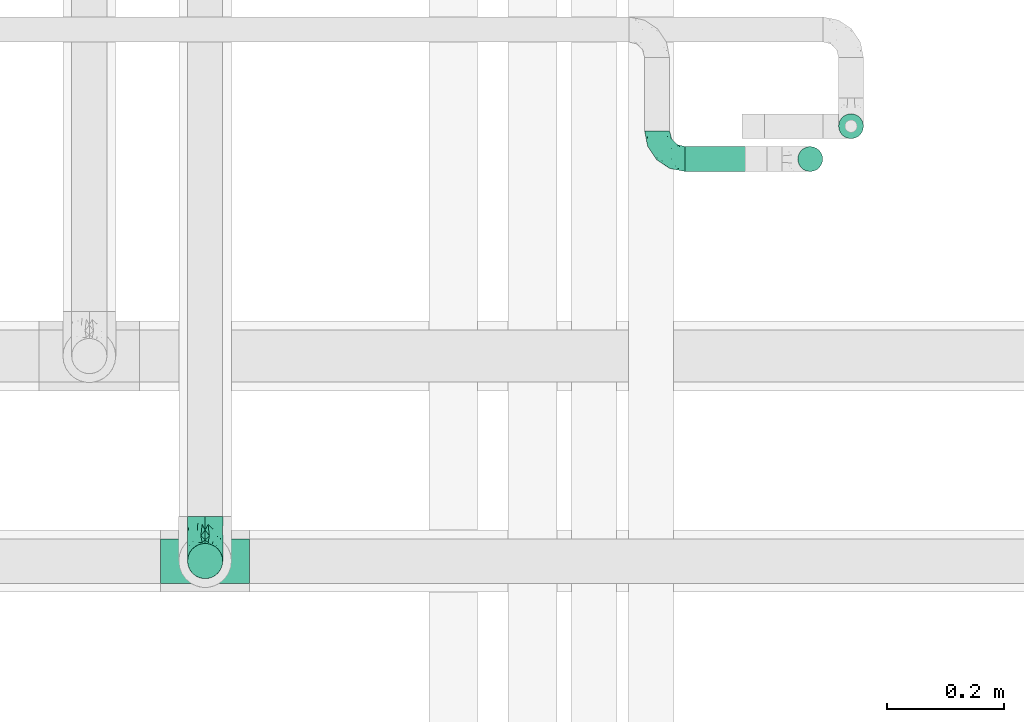
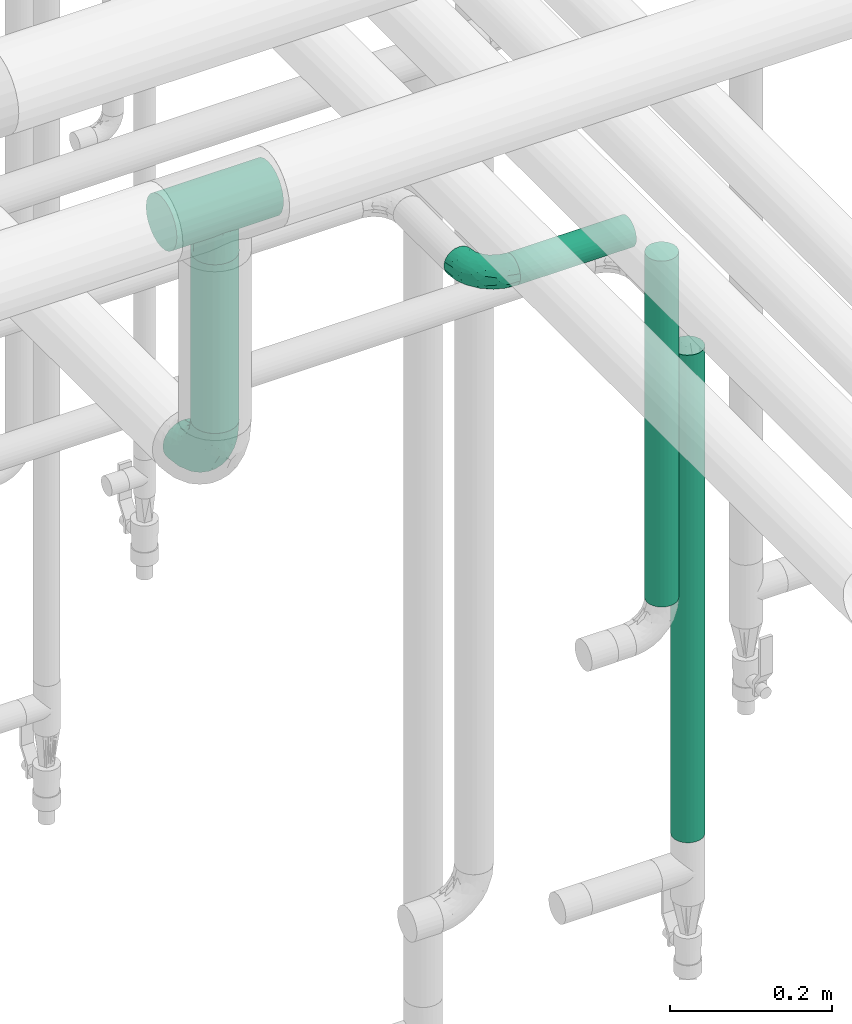
# One storey, part 574 of 824: 4 flow segments, 3 flow fittings.
"""IFC2X3 building model written with IfcOpenShell, lengths in millimetres."""

from ifc_helpers import new_model, entity, si_unit, converted_unit, derived_unit, direction, frame, origin, origin_2d_with_axis, place, context, subcontext, project, spatial, circle, extrude, faceted_brep, source, transform, mapped, material, type_object, type_shapes, element, save


model = new_model("IFC2X3")

# Units and contexts
model_context = context("Model", 3, precision=0.01, world=origin(), true_north=direction((6.12303176911189e-17, 1.0)))
body_context = subcontext(model_context, "Body", "Model", "MODEL_VIEW")
ifc_project = project(units=[si_unit("LENGTHUNIT", "METRE", prefix="MILLI"), si_unit("AREAUNIT", "SQUARE_METRE"), si_unit("VOLUMEUNIT", "CUBIC_METRE"), converted_unit("PLANEANGLEUNIT", "DEGREE", entity("IfcRatioMeasure", 0.0174532925199433), si_unit("PLANEANGLEUNIT", "RADIAN"), dimensions=[0, 0, 0, 0, 0, 0, 0]), si_unit("MASSUNIT", "GRAM", prefix="KILO"), derived_unit("MASSDENSITYUNIT", [(si_unit("MASSUNIT", "GRAM", prefix="KILO"), 1), (si_unit("LENGTHUNIT", "METRE"), -3)]), derived_unit("MOMENTOFINERTIAUNIT", [(si_unit("LENGTHUNIT", "METRE"), 4)]), si_unit("TIMEUNIT", "SECOND"), si_unit("FREQUENCYUNIT", "HERTZ"), si_unit("THERMODYNAMICTEMPERATUREUNIT", "DEGREE_CELSIUS"), derived_unit("THERMALTRANSMITTANCEUNIT", [(si_unit("MASSUNIT", "GRAM", prefix="KILO"), 1), (si_unit("THERMODYNAMICTEMPERATUREUNIT", "KELVIN"), -1), (si_unit("TIMEUNIT", "SECOND"), -3)]), derived_unit("VOLUMETRICFLOWRATEUNIT", [(si_unit("LENGTHUNIT", "METRE"), 3), (si_unit("TIMEUNIT", "SECOND"), -1)]), derived_unit("MASSFLOWRATEUNIT", [(si_unit("MASSUNIT", "GRAM", prefix="KILO"), 1), (si_unit("TIMEUNIT", "SECOND"), -1)]), derived_unit("ROTATIONALFREQUENCYUNIT", [(si_unit("TIMEUNIT", "SECOND"), -1)]), si_unit("ELECTRICCURRENTUNIT", "AMPERE"), si_unit("ELECTRICVOLTAGEUNIT", "VOLT"), si_unit("POWERUNIT", "WATT"), si_unit("FORCEUNIT", "NEWTON", prefix="KILO"), si_unit("ILLUMINANCEUNIT", "LUX"), si_unit("LUMINOUSFLUXUNIT", "LUMEN"), si_unit("LUMINOUSINTENSITYUNIT", "CANDELA"), derived_unit("USERDEFINED", [(si_unit("MASSUNIT", "GRAM", prefix="KILO"), -1), (si_unit("LENGTHUNIT", "METRE"), -2), (si_unit("TIMEUNIT", "SECOND"), 3), (si_unit("LUMINOUSFLUXUNIT", "LUMEN"), 1)]), derived_unit("LINEARVELOCITYUNIT", [(si_unit("LENGTHUNIT", "METRE"), 1), (si_unit("TIMEUNIT", "SECOND"), -1)]), si_unit("PRESSUREUNIT", "PASCAL"), derived_unit("USERDEFINED", [(si_unit("LENGTHUNIT", "METRE"), -2), (si_unit("MASSUNIT", "GRAM", prefix="KILO"), 1), (si_unit("TIMEUNIT", "SECOND"), -2)]), derived_unit("LINEARFORCEUNIT", [(si_unit("MASSUNIT", "GRAM", prefix="KILO"), 1), (si_unit("LENGTHUNIT", "METRE"), 1), (si_unit("TIMEUNIT", "SECOND"), -2), (si_unit("LENGTHUNIT", "METRE"), -1)]), derived_unit("PLANARFORCEUNIT", [(si_unit("MASSUNIT", "GRAM", prefix="KILO"), 1), (si_unit("LENGTHUNIT", "METRE"), 1), (si_unit("TIMEUNIT", "SECOND"), -2), (si_unit("LENGTHUNIT", "METRE"), -2)])], contexts=[model_context])

# Site, building, storey
site_placement = place(None, origin())
site = spatial("IfcSite", under=ifc_project, at=site_placement, CompositionType="ELEMENT")
building_placement = place(site_placement, origin())
building = spatial("IfcBuilding", under=site, at=building_placement, CompositionType="ELEMENT")
storey_placement = place(building_placement, frame((0.0, 0.0, 28200.0)))
storey = spatial("IfcBuildingStorey", under=building, at=storey_placement, CompositionType="ELEMENT", Elevation=28200.0)

# Flow segments
pipe_segment_type = type_object("IfcPipeSegmentType", PredefinedType="NOTDEFINED")
flow_segment_1_placement = place(storey_placement, frame((19001.31, 15119.04, 1018.11)))
element("IfcFlowSegment", 1, at=flow_segment_1_placement, inside=storey, type_object=pipe_segment_type, context=body_context, shape_type="SweptSolid", body=[
    extrude(circle(Radius=21.15, at=origin_2d_with_axis()), frame((22.75, 22.75, 0.0)), (0.0, 0.0, 1.0), 733.894998191936),
])
flow_segment_2_placement = place(storey_placement, frame((18741.2, 15063.0, 1977.25)))
element("IfcFlowSegment", 2, at=flow_segment_2_placement, inside=storey, type_object=pipe_segment_type, context=body_context, shape_type="SweptSolid", body=[
    extrude(circle(Radius=21.15, at=origin_2d_with_axis()), frame((0.0, 22.75, 22.75), z_axis=(1.0, 0.0, 0.0), x_axis=(0.0, -1.0, 0.0)), (0.0, 0.0, 1.0), 165.253426009053),
])
flow_segment_3_placement = place(storey_placement, frame((17890.7, 14368.4, 2476.0)))
element("IfcFlowSegment", 3, at=flow_segment_3_placement, inside=storey, type_object=pipe_segment_type, context=body_context, shape_type="SweptSolid", body=[
    extrude(circle(Radius=30.0, at=origin_2d_with_axis()), frame((31.6, 31.6, 0.0)), (0.0, 0.0, 1.0), 253.982896996899),
])
flow_segment_4_placement = place(storey_placement, frame((18931.71, 15063.0, 1431.37)))
element("IfcFlowSegment", 4, at=flow_segment_4_placement, inside=storey, type_object=pipe_segment_type, context=body_context, shape_type="SweptSolid", body=[
    extrude(circle(Radius=21.15, at=origin_2d_with_axis()), frame((22.75, 22.75, 0.0), z_axis=(0.0, 0.0, 1.0), x_axis=(-1.0, 0.0, 0.0)), (0.0, 0.0, 1.0), 520.625971677545),
])

# Flow fittings
ifc_material = material()
pipe_fitting_type_1 = type_object("IfcPipeFittingType", PredefinedType="NOTDEFINED", material=ifc_material)
shared_shape_1 = source(origin(), body_context, "Body", "Brep", [
    faceted_brep([(-48.0, 10.6, -18.36), (-48.0, 5.49, -20.48), (-48.0, 0.0, -21.2), (-48.0, -5.49, -20.48), (-48.0, -10.6, -18.36), (-48.0, -14.99, -14.99), (-48.0, -18.36, -10.6), (-48.0, -20.48, -5.49), (-48.0, -21.2, 0.0), (-48.0, -20.48, 5.49), (-48.0, -18.36, 10.6), (-48.0, -14.99, 14.99), (-48.0, -10.6, 18.36), (-48.0, -5.49, 20.48), (-48.0, 0.0, 21.2), (-48.0, 5.49, 20.48), (-48.0, 10.6, 18.36), (-48.0, 14.99, 14.99), (-48.0, 18.36, 10.6), (-48.0, 20.48, 5.49), (-48.0, 21.2, 0.0), (-48.0, 20.48, -5.49), (-48.0, 18.36, -10.6), (-48.0, 14.99, -14.99), (0.0, 48.0, -21.2), (-5.49, 48.0, -20.48), (-10.6, 48.0, -18.36), (-14.99, 48.0, -14.99), (-18.36, 48.0, -10.6), (-20.48, 48.0, -5.49), (-21.2, 48.0, 0.0), (-20.48, 48.0, 5.49), (-18.36, 48.0, 10.6), (-14.99, 48.0, 14.99), (-10.6, 48.0, 18.36), (-5.49, 48.0, 20.48), (0.0, 48.0, 21.2), (5.49, 48.0, 20.48), (10.6, 48.0, 18.36), (14.99, 48.0, 14.99), (18.36, 48.0, 10.6), (20.48, 48.0, 5.49), (21.2, 48.0, 0.0), (20.48, 48.0, -5.49), (18.36, 48.0, -10.6), (14.99, 48.0, -14.99), (10.6, 48.0, -18.36), (5.49, 48.0, -20.48), (-35.25, -16.22, 12.01), (-34.76, -18.57, 0.0), (-20.87, -12.37, 10.9), (-31.49, -11.78, 15.9), (-37.0, -2.58, 20.86), (-33.89, 3.62, 21.15), (-31.81, -18.14, 6.76), (-5.78, 5.78, 17.67), (-19.42, -4.1, 17.86), (-9.6, -3.39, 13.73), (-35.44, -7.73, 19.13), (11.78, 31.49, 15.9), (-5.93, -5.46, 6.95), (-18.45, -13.78, 5.46), (-10.29, -8.43, 0.0), (-24.6, 0.55, 20.62), (-37.28, 17.94, 13.81), (-33.38, 22.85, 9.59), (-41.46, 20.06, 8.75), (-29.51, 20.45, 15.16), (-15.04, 10.79, 21.13), (-7.08, 16.98, 20.93), (-8.39, 23.51, 21.15), (-40.86, 13.03, 17.26), (-8.05, 41.26, 19.83), (-3.21, 35.97, 21.14), (8.53, 19.66, 14.74), (4.1, 19.42, 17.86), (-37.72, 22.66, 4.78), (-37.07, 8.58, 19.98), (-13.0, 5.43, 19.97), (-3.78, 13.93, 19.7), (3.02, 8.69, 13.43), (-2.27, -0.05, 10.65), (6.22, 6.99, 7.09), (-22.25, 34.6, 9.45), (18.14, 31.81, 6.76), (16.22, 35.25, 12.01), (12.37, 20.87, 10.9), (7.73, 35.44, 19.13), (-21.52, -15.93, 0.0), (2.58, 37.0, 20.86), (18.57, 34.76, 0.0), (13.78, 18.45, 5.46), (15.93, 21.52, 0.0), (-20.03, -8.54, 14.9), (-28.6, 28.6, 5.16), (-24.79, 34.6, 0.0), (-34.6, 24.79, 0.0), (-22.81, 37.41, 4.68), (-23.36, 26.33, 14.79), (-13.68, 37.05, 17.49), (-17.72, 38.12, 13.73), (-26.25, 27.3, 11.24), (-9.71, 32.34, 20.14), (-17.26, 25.6, 18.71), (-26.33, 9.99, 20.77), (-24.06, 6.05, 21.2), (-25.02, 15.46, 19.56), (-24.3, 20.72, 17.57), (-31.95, 15.23, 17.8), (-13.53, 24.7, 20.21), (-17.6, 17.6, 20.6), (-0.55, 24.6, 20.62), (-11.41, -7.48, 10.43), (0.93, -0.93, 0.0), (8.43, 10.29, 0.0), (-11.41, -7.48, -10.43), (-20.1, -8.84, -14.66), (-9.6, -3.39, -13.73), (7.73, 35.44, -19.13), (4.1, 19.42, -17.86), (-0.55, 24.6, -20.62), (-38.12, 17.72, -13.73), (-37.05, 13.68, -17.49), (-32.34, 9.71, -20.14), (-41.26, 8.05, -19.83), (-37.41, 22.81, -4.68), (-23.51, 8.39, -21.15), (-35.97, 3.21, -21.14), (-28.6, 28.6, -5.16), (-31.81, -18.14, -6.76), (-18.45, -13.78, -5.46), (-25.6, 17.26, -18.71), (-19.42, -4.1, -17.86), (-17.94, 37.28, -13.81), (-22.85, 33.38, -9.59), (-20.06, 41.46, -8.75), (-31.49, -11.78, -15.9), (-35.25, -16.22, -12.01), (8.53, 19.66, -14.74), (11.78, 31.49, -15.9), (-9.99, 26.33, -20.77), (-6.05, 24.06, -21.2), (-10.79, 15.04, -21.13), (-37.0, -2.58, -20.86), (-16.98, 7.08, -20.93), (-5.43, 13.0, -19.97), (-13.93, 3.78, -19.7), (-20.87, -12.37, -10.9), (-26.33, 23.36, -14.79), (-22.66, 37.72, -4.78), (13.78, 18.45, -5.46), (18.14, 31.81, -6.76), (-15.46, 25.02, -19.56), (-20.72, 24.3, -17.57), (16.22, 35.25, -12.01), (-13.03, 40.86, -17.26), (-8.58, 37.07, -19.98), (2.58, 37.0, -20.86), (-3.62, 33.89, -21.15), (-34.6, 22.25, -9.45), (6.22, 6.99, -7.09), (-20.45, 29.51, -15.16), (-35.44, -7.73, -19.13), (12.37, 20.87, -10.9), (-27.3, 26.25, -11.24), (-15.23, 31.95, -17.8), (-24.7, 13.53, -20.21), (-24.6, 0.55, -20.62), (-5.78, 5.78, -17.67), (-17.6, 17.6, -20.6), (3.02, 8.69, -13.43), (-5.93, -5.46, -6.95), (-2.27, -0.05, -10.65)], [[[0, 1, 2, 3, 4, 5, 6, 7, 8, 9, 10, 11, 12, 13, 14, 15, 16, 17, 18, 19, 20, 21, 22, 23]], [[24, 25, 26, 27, 28, 29, 30, 31, 32, 33, 34, 35, 36, 37, 38, 39, 40, 41, 42, 43, 44, 45, 46, 47]], [[10, 48, 11]], [[9, 8, 49]], [[48, 50, 51]], [[14, 52, 53]], [[10, 54, 48]], [[9, 54, 10]], [[55, 56, 57]], [[51, 12, 11]], [[51, 58, 12]], [[59, 39, 38]], [[60, 61, 62]], [[58, 56, 63]], [[64, 65, 66]], [[67, 65, 64]], [[68, 69, 70]], [[16, 71, 17]], [[13, 52, 14]], [[35, 72, 73]], [[14, 53, 15]], [[17, 64, 18]], [[74, 59, 75]], [[20, 19, 76]], [[66, 19, 18]], [[77, 15, 53]], [[15, 77, 16]], [[69, 78, 79]], [[80, 81, 82]], [[32, 31, 83]], [[84, 85, 86]], [[59, 87, 75]], [[61, 54, 88]], [[36, 89, 37]], [[84, 41, 40]], [[36, 35, 73]], [[90, 41, 84]], [[40, 39, 85]], [[12, 58, 13]], [[85, 84, 40]], [[91, 84, 86]], [[84, 92, 90]], [[87, 38, 37]], [[93, 56, 51]], [[65, 94, 76]], [[94, 95, 96]], [[84, 91, 92]], [[95, 97, 30]], [[98, 99, 100]], [[76, 94, 96]], [[101, 98, 83]], [[100, 99, 33]], [[102, 70, 73]], [[103, 102, 99]], [[94, 97, 95]], [[72, 99, 102]], [[72, 35, 34]], [[34, 33, 99]], [[9, 49, 54]], [[87, 59, 38]], [[104, 105, 68]], [[106, 103, 107]], [[106, 77, 104]], [[71, 64, 17]], [[108, 107, 67]], [[33, 32, 100]], [[109, 103, 110]], [[102, 109, 70]], [[89, 73, 111]], [[50, 48, 54]], [[51, 11, 48]], [[56, 58, 51]], [[88, 54, 49]], [[52, 58, 63]], [[50, 112, 93]], [[56, 55, 78]], [[39, 59, 85]], [[86, 85, 59]], [[89, 87, 37]], [[42, 41, 90]], [[111, 79, 75]], [[111, 75, 87]], [[75, 55, 80]], [[104, 77, 53]], [[71, 77, 108]], [[32, 83, 100]], [[98, 100, 83]], [[99, 98, 103]], [[106, 107, 108]], [[68, 70, 110]], [[111, 73, 70]], [[68, 110, 104]], [[68, 63, 78]], [[57, 93, 112]], [[80, 55, 57]], [[61, 50, 54]], [[80, 82, 86]], [[81, 57, 112]], [[74, 86, 59]], [[60, 113, 82]], [[82, 114, 91]], [[101, 94, 65]], [[97, 94, 83]], [[73, 89, 36]], [[87, 89, 111]], [[58, 52, 13]], [[53, 52, 63]], [[104, 53, 105]], [[106, 104, 110]], [[20, 76, 96]], [[76, 19, 66]], [[103, 106, 110]], [[77, 106, 108]], [[103, 98, 107]], [[67, 107, 98]], [[67, 98, 101]], [[108, 67, 64]], [[53, 63, 105]], [[63, 68, 105]], [[83, 31, 97]], [[30, 97, 31]], [[62, 113, 60]], [[112, 61, 60]], [[61, 88, 62]], [[86, 82, 91]], [[56, 78, 63]], [[114, 82, 113]], [[114, 92, 91]], [[79, 78, 55]], [[75, 79, 55]], [[69, 79, 111]], [[70, 69, 111]], [[78, 69, 68]], [[77, 71, 16]], [[64, 71, 108]], [[64, 66, 18]], [[76, 66, 65]], [[99, 72, 34]], [[73, 72, 102]], [[94, 101, 83]], [[67, 101, 65]], [[75, 80, 74]], [[80, 86, 74]], [[70, 109, 110]], [[102, 103, 109]], [[50, 93, 51]], [[57, 56, 93]], [[61, 112, 50]], [[81, 112, 60]], [[82, 81, 60]], [[80, 57, 81]], [[115, 116, 117]], [[118, 119, 120]], [[121, 122, 23]], [[123, 124, 122]], [[96, 125, 20]], [[123, 126, 127]], [[128, 96, 95]], [[129, 130, 88]], [[123, 122, 131]], [[116, 132, 117]], [[133, 134, 135]], [[0, 124, 1]], [[5, 136, 137]], [[138, 119, 139]], [[129, 88, 49]], [[140, 141, 142]], [[6, 5, 137]], [[46, 118, 47]], [[143, 3, 2]], [[144, 145, 146]], [[6, 129, 7]], [[129, 137, 147]], [[127, 2, 1]], [[148, 122, 121]], [[128, 125, 96]], [[134, 128, 149]], [[95, 149, 128]], [[150, 151, 92]], [[30, 29, 149]], [[152, 131, 153]], [[27, 133, 28]], [[154, 45, 44]], [[136, 5, 4]], [[27, 26, 155]], [[156, 26, 25]], [[24, 157, 158]], [[24, 47, 157]], [[22, 21, 159]], [[160, 150, 114]], [[134, 133, 161]], [[142, 144, 126]], [[46, 139, 118]], [[162, 136, 4]], [[156, 25, 158]], [[1, 124, 127]], [[115, 147, 116]], [[45, 154, 139]], [[139, 46, 45]], [[154, 163, 139]], [[162, 4, 3]], [[42, 90, 43]], [[130, 129, 147]], [[49, 7, 129]], [[43, 151, 44]], [[0, 23, 122]], [[24, 158, 25]], [[136, 162, 132]], [[135, 29, 28]], [[43, 90, 151]], [[164, 148, 159]], [[152, 156, 140]], [[155, 133, 27]], [[165, 153, 161]], [[23, 22, 121]], [[123, 131, 166]], [[123, 166, 126]], [[143, 127, 167]], [[147, 137, 136]], [[8, 7, 49]], [[129, 6, 137]], [[143, 162, 3]], [[167, 146, 132]], [[167, 132, 162]], [[132, 168, 117]], [[44, 151, 154]], [[92, 151, 90]], [[163, 154, 151]], [[119, 118, 139]], [[157, 118, 120]], [[138, 139, 163]], [[119, 168, 145]], [[140, 156, 158]], [[155, 156, 165]], [[22, 159, 121]], [[148, 121, 159]], [[122, 148, 131]], [[152, 153, 165]], [[142, 126, 169]], [[167, 127, 126]], [[142, 169, 140]], [[142, 120, 145]], [[168, 170, 117]], [[160, 171, 172]], [[115, 172, 171]], [[171, 62, 130]], [[119, 170, 168]], [[170, 163, 160]], [[150, 163, 151]], [[113, 171, 160]], [[164, 128, 134]], [[125, 128, 159]], [[127, 143, 2]], [[162, 143, 167]], [[118, 157, 47]], [[158, 157, 120]], [[140, 158, 141]], [[152, 140, 169]], [[30, 149, 95]], [[149, 29, 135]], [[131, 152, 169]], [[156, 152, 165]], [[131, 148, 153]], [[161, 153, 148]], [[161, 148, 164]], [[165, 161, 133]], [[158, 120, 141]], [[120, 142, 141]], [[159, 21, 125]], [[20, 125, 21]], [[115, 130, 147]], [[114, 113, 160]], [[62, 171, 113]], [[62, 88, 130]], [[160, 163, 150]], [[150, 92, 114]], [[119, 145, 120]], [[146, 145, 168]], [[132, 146, 168]], [[144, 146, 167]], [[126, 144, 167]], [[145, 144, 142]], [[156, 155, 26]], [[133, 155, 165]], [[133, 135, 28]], [[149, 135, 134]], [[122, 124, 0]], [[127, 124, 123]], [[128, 164, 159]], [[161, 164, 134]], [[163, 170, 138]], [[170, 119, 138]], [[131, 169, 166]], [[126, 166, 169]], [[147, 136, 116]], [[132, 116, 136]], [[172, 115, 117]], [[130, 115, 171]], [[117, 170, 172]], [[160, 172, 170]]]),
])
type_shapes(pipe_fitting_type_1, [shared_shape_1])
flow_fitting_1_placement = place(storey_placement, frame((18693.2, 15085.74, 2000.0), z_axis=(0.0, 0.0, 1.0), x_axis=(0.0, -1.0, 0.0)))
element("IfcFlowFitting", 5, at=flow_fitting_1_placement, inside=storey, type_object=pipe_fitting_type_1, material=ifc_material, context=body_context, shape_type="MappedRepresentation", body=[
    mapped(shared_shape_1, transform((0.0, 0.0, 0.0), scale=1.0)),
])
pipe_fitting_type_2 = type_object("IfcPipeFittingType", PredefinedType="NOTDEFINED", material=ifc_material)
shared_shape_2 = source(origin(), body_context, "Body", "Brep", [
    faceted_brep([(-76.0, 15.07, -26.11), (-76.0, 7.8, -29.12), (-76.0, 0.0, -30.15), (-76.0, -7.8, -29.12), (-76.0, -15.08, -26.11), (-76.0, -21.32, -21.32), (-76.0, -26.11, -15.08), (-76.0, -29.12, -7.8), (-76.0, -30.15, 0.0), (-76.0, -29.12, 7.8), (-76.0, -26.11, 15.07), (-76.0, -21.32, 21.32), (-76.0, -15.08, 26.11), (-76.0, -7.8, 29.12), (-76.0, 0.0, 30.15), (-76.0, 7.8, 29.12), (-76.0, 15.07, 26.11), (-76.0, 21.32, 21.32), (-76.0, 26.11, 15.07), (-76.0, 29.12, 7.8), (-76.0, 30.15, 0.0), (-76.0, 29.12, -7.8), (-76.0, 26.11, -15.08), (-76.0, 21.32, -21.32), (0.0, 76.0, -30.15), (-7.8, 76.0, -29.12), (-15.07, 76.0, -26.11), (-21.32, 76.0, -21.32), (-26.11, 76.0, -15.08), (-29.12, 76.0, -7.8), (-30.15, 76.0, 0.0), (-29.12, 76.0, 7.8), (-26.11, 76.0, 15.07), (-21.32, 76.0, 21.32), (-15.07, 76.0, 26.11), (-7.8, 76.0, 29.12), (0.0, 76.0, 30.15), (7.8, 76.0, 29.12), (15.08, 76.0, 26.11), (21.32, 76.0, 21.32), (26.11, 76.0, 15.07), (29.12, 76.0, 7.8), (30.15, 76.0, 0.0), (29.12, 76.0, -7.8), (26.11, 76.0, -15.08), (21.32, 76.0, -21.32), (15.08, 76.0, -26.11), (7.8, 76.0, -29.12), (10.79, 31.43, 21.07), (4.32, 31.7, 25.72), (1.65, 15.19, 19.92), (-61.17, -27.8, 0.0), (-51.1, -25.49, 9.84), (-56.14, -10.61, 27.27), (-31.7, -4.32, 25.72), (-39.75, 1.72, 29.41), (-43.2, -24.95, 0.0), (-1.86, 1.86, 0.0), (4.49, 7.65, 5.78), (-7.82, -4.61, 5.83), (-56.21, -22.79, 17.21), (-58.98, -3.38, 29.7), (-53.96, 5.6, 30.07), (-10.86, 10.86, 25.48), (-17.2, -2.6, 20.44), (-49.15, -16.01, 22.7), (-22.18, -14.24, 7.99), (-28.4, -17.42, 0.0), (-13.61, -9.88, 0.0), (-39.0, 23.48, 27.76), (-58.76, 12.54, 28.36), (-41.61, 15.41, 29.48), (16.01, 49.15, 22.7), (-58.55, 25.93, 19.53), (-51.53, 33.5, 13.51), (-64.92, 28.76, 12.4), (-7.48, 23.14, 28.25), (-1.72, 39.75, 29.41), (-12.04, 27.88, 29.88), (-63.91, 18.81, 24.52), (-11.63, 65.16, 28.18), (-4.97, 57.02, 30.05), (9.88, 13.61, 0.0), (-62.5, 31.74, 5.02), (-45.17, 30.98, 21.2), (-21.78, 9.76, 28.58), (10.61, 56.14, 27.27), (-32.09, 54.42, 13.26), (22.79, 56.21, 17.21), (15.38, 31.17, 15.63), (25.49, 51.1, 9.84), (21.84, 36.35, 5.92), (24.95, 43.2, 0.0), (3.38, 58.98, 29.7), (-31.17, -15.38, 15.63), (-39.39, 41.78, 15.45), (-34.56, 41.13, 20.79), (-39.81, -23.25, 5.49), (27.8, 61.17, 0.0), (-31.74, 62.5, 5.02), (-53.07, 36.29, 0.0), (-42.95, 42.95, 7.29), (-36.29, 53.07, 0.0), (-19.83, 58.51, 24.79), (-25.48, 60.2, 19.41), (-14.53, 50.96, 28.57), (-13.31, 37.09, 30.07), (-26.16, 40.06, 26.4), (-32.43, -10.35, 21.9), (17.42, 28.4, 0.0), (14.24, 22.18, 7.99), (-38.67, 9.72, 30.15), (-24.66, 17.36, 30.09), (-37.08, 31.49, 24.99), (-49.27, 22.83, 25.24), (-20.8, 38.81, 28.63), (-27.58, 27.58, 29.2), (-36.07, -20.23, 10.71), (-15.19, -6.16, 14.9), (6.6, 15.4, 14.49), (-2.51, 2.51, 11.35), (-65.16, 11.63, -28.18), (-49.15, -16.01, -22.7), (-57.02, 4.97, -30.05), (-25.93, 58.55, -19.53), (-33.5, 51.53, -13.51), (-28.76, 64.92, -12.4), (-60.2, 25.48, -19.41), (-58.51, 19.83, -24.79), (4.61, 7.82, -5.83), (-7.65, -4.49, -5.78), (-2.51, 2.51, -11.35), (-62.5, 31.74, -5.02), (-50.96, 14.53, -28.57), (-37.09, 13.31, -30.07), (-42.95, 42.95, -7.29), (25.49, 51.1, -9.84), (22.79, 56.21, -17.21), (-40.06, 26.16, -26.4), (3.38, 58.98, -29.7), (-5.6, 53.96, -30.07), (-27.88, 12.04, -29.88), (-9.76, 21.78, -28.58), (-23.14, 7.48, -28.25), (-51.1, -25.49, -9.84), (15.38, 31.17, -15.63), (16.01, 49.15, -22.7), (-23.48, 39.0, -27.76), (-12.54, 58.76, -28.36), (-15.41, 41.61, -29.48), (-56.21, -22.79, -17.21), (-9.72, 38.67, -30.15), (-17.36, 24.66, -30.09), (-22.18, -14.24, -7.99), (-41.13, 34.56, -20.79), (-31.74, 62.5, -5.02), (-58.98, -3.38, -29.7), (-31.17, -15.38, -15.63), (-56.14, -10.61, -27.27), (14.24, 22.18, -7.99), (23.25, 39.81, -5.49), (-31.49, 37.08, -24.99), (-15.19, -6.16, -14.9), (1.65, 15.19, -19.92), (-18.81, 63.91, -24.52), (-32.59, -11.62, -20.84), (-31.7, -4.32, -25.72), (-17.2, -2.6, -20.44), (-39.75, 1.72, -29.41), (-54.42, 32.09, -13.26), (-30.98, 45.17, -21.2), (10.61, 56.14, -27.27), (10.23, 31.31, -21.52), (4.32, 31.7, -25.72), (-41.78, 39.39, -15.45), (-1.72, 39.75, -29.41), (-36.35, -21.84, -5.92), (-22.83, 49.27, -25.24), (-38.81, 20.8, -28.63), (-27.58, 27.58, -29.2), (-10.86, 10.86, -25.48), (20.23, 36.07, -10.71), (6.6, 15.4, -14.49)], [[[0, 1, 2, 3, 4, 5, 6, 7, 8, 9, 10, 11, 12, 13, 14, 15, 16, 17, 18, 19, 20, 21, 22, 23]], [[24, 25, 26, 27, 28, 29, 30, 31, 32, 33, 34, 35, 36, 37, 38, 39, 40, 41, 42, 43, 44, 45, 46, 47]], [[48, 49, 50]], [[51, 52, 9]], [[53, 54, 55]], [[9, 52, 10]], [[56, 52, 51]], [[57, 58, 59]], [[11, 10, 60]], [[14, 61, 62]], [[63, 54, 64]], [[65, 12, 11]], [[65, 53, 12]], [[66, 67, 68]], [[69, 70, 71]], [[72, 39, 38]], [[73, 74, 75]], [[15, 70, 16]], [[76, 77, 78]], [[16, 79, 17]], [[13, 61, 14]], [[35, 80, 81]], [[14, 62, 15]], [[17, 73, 18]], [[57, 82, 58]], [[20, 19, 83]], [[75, 19, 18]], [[70, 15, 62]], [[73, 84, 74]], [[78, 85, 76]], [[38, 86, 72]], [[32, 31, 87]], [[88, 89, 90]], [[91, 92, 90]], [[72, 86, 49]], [[36, 93, 37]], [[75, 83, 19]], [[36, 35, 81]], [[60, 94, 65]], [[40, 90, 41]], [[95, 96, 87]], [[88, 90, 40]], [[66, 97, 67]], [[90, 98, 41]], [[40, 39, 88]], [[99, 31, 30]], [[20, 83, 100]], [[101, 102, 100]], [[52, 60, 10]], [[102, 99, 30]], [[96, 103, 104]], [[83, 101, 100]], [[12, 53, 13]], [[104, 103, 33]], [[105, 106, 81]], [[107, 105, 103]], [[64, 54, 108]], [[80, 103, 105]], [[80, 35, 34]], [[34, 33, 103]], [[86, 38, 37]], [[109, 110, 82]], [[71, 111, 112]], [[69, 107, 113]], [[79, 73, 17]], [[114, 113, 84]], [[33, 32, 104]], [[115, 107, 116]], [[105, 115, 106]], [[93, 81, 77]], [[54, 53, 65]], [[61, 53, 55]], [[108, 94, 64]], [[54, 63, 85]], [[93, 86, 37]], [[77, 76, 49]], [[77, 49, 86]], [[49, 63, 50]], [[60, 52, 117]], [[65, 11, 60]], [[39, 72, 88]], [[89, 88, 72]], [[71, 70, 62]], [[79, 70, 114]], [[103, 96, 107]], [[69, 113, 114]], [[112, 106, 116]], [[77, 81, 106]], [[112, 116, 71]], [[112, 55, 85]], [[64, 50, 63]], [[57, 59, 68]], [[32, 87, 104]], [[96, 104, 87]], [[94, 118, 64]], [[50, 119, 89]], [[50, 64, 118]], [[50, 89, 48]], [[81, 93, 36]], [[86, 93, 77]], [[53, 61, 13]], [[62, 61, 55]], [[71, 62, 111]], [[69, 71, 116]], [[95, 101, 74]], [[99, 101, 87]], [[118, 66, 59]], [[117, 97, 66]], [[117, 66, 94]], [[91, 89, 110]], [[91, 110, 109]], [[110, 89, 119]], [[9, 8, 51]], [[98, 90, 92]], [[98, 42, 41]], [[101, 83, 74]], [[101, 99, 102]], [[87, 31, 99]], [[62, 55, 111]], [[55, 112, 111]], [[107, 69, 116]], [[70, 69, 114]], [[107, 96, 113]], [[84, 113, 96]], [[84, 96, 95]], [[114, 84, 73]], [[70, 79, 16]], [[73, 79, 114]], [[54, 85, 55]], [[76, 85, 63]], [[49, 76, 63]], [[77, 106, 78]], [[106, 112, 78]], [[85, 78, 112]], [[73, 75, 18]], [[83, 75, 74]], [[103, 80, 34]], [[81, 80, 105]], [[101, 95, 87]], [[84, 95, 74]], [[106, 115, 116]], [[105, 107, 115]], [[120, 59, 58]], [[82, 110, 58]], [[119, 58, 110]], [[118, 59, 120]], [[66, 68, 59]], [[54, 65, 108]], [[94, 108, 65]], [[66, 118, 94]], [[50, 118, 120]], [[50, 120, 119]], [[119, 120, 58]], [[89, 72, 48]], [[49, 48, 72]], [[60, 117, 94]], [[117, 52, 97]], [[52, 56, 97]], [[67, 97, 56]], [[92, 91, 109]], [[89, 91, 90]], [[121, 1, 0]], [[122, 5, 4]], [[2, 1, 123]], [[124, 125, 126]], [[127, 128, 23]], [[129, 130, 131]], [[100, 132, 20]], [[133, 134, 123]], [[135, 100, 102]], [[136, 137, 44]], [[133, 128, 138]], [[24, 139, 140]], [[141, 142, 143]], [[121, 128, 133]], [[6, 144, 7]], [[137, 145, 146]], [[144, 51, 7]], [[147, 148, 149]], [[144, 6, 150]], [[149, 151, 152]], [[153, 68, 67]], [[154, 128, 127]], [[30, 155, 102]], [[43, 42, 98]], [[156, 3, 2]], [[157, 144, 150]], [[158, 4, 3]], [[24, 140, 25]], [[155, 135, 102]], [[159, 160, 109]], [[30, 29, 155]], [[147, 138, 161]], [[27, 124, 28]], [[57, 129, 82]], [[162, 163, 131]], [[27, 26, 164]], [[148, 26, 25]], [[165, 166, 167]], [[24, 47, 139]], [[143, 168, 141]], [[22, 21, 169]], [[125, 124, 170]], [[148, 25, 140]], [[46, 146, 171]], [[158, 122, 4]], [[0, 23, 128]], [[1, 121, 123]], [[109, 82, 159]], [[45, 44, 137]], [[146, 46, 45]], [[136, 43, 98]], [[132, 21, 20]], [[136, 98, 92]], [[172, 173, 146]], [[46, 171, 47]], [[43, 136, 44]], [[174, 154, 169]], [[171, 173, 175]], [[6, 5, 150]], [[126, 29, 28]], [[176, 56, 144]], [[122, 158, 166]], [[164, 124, 27]], [[177, 161, 170]], [[23, 22, 127]], [[178, 138, 179]], [[133, 178, 134]], [[156, 123, 168]], [[156, 158, 3]], [[168, 143, 166]], [[168, 166, 158]], [[166, 180, 167]], [[173, 171, 146]], [[139, 171, 175]], [[172, 145, 163]], [[173, 180, 142]], [[5, 122, 150]], [[157, 150, 122]], [[137, 136, 181]], [[146, 45, 137]], [[149, 148, 140]], [[164, 148, 177]], [[128, 154, 138]], [[147, 161, 177]], [[152, 134, 179]], [[168, 123, 134]], [[152, 179, 149]], [[152, 175, 142]], [[57, 130, 129]], [[157, 165, 167]], [[22, 169, 127]], [[154, 127, 169]], [[163, 167, 180]], [[162, 157, 167]], [[173, 163, 180]], [[182, 163, 145]], [[123, 156, 2]], [[158, 156, 168]], [[171, 139, 47]], [[140, 139, 175]], [[149, 140, 151]], [[147, 149, 179]], [[174, 135, 125]], [[132, 135, 169]], [[176, 157, 153]], [[176, 153, 67]], [[153, 157, 162]], [[182, 159, 129]], [[181, 160, 159]], [[181, 159, 145]], [[51, 144, 56]], [[51, 8, 7]], [[135, 132, 100]], [[169, 21, 132]], [[126, 155, 29]], [[135, 155, 125]], [[140, 175, 151]], [[175, 152, 151]], [[138, 147, 179]], [[148, 147, 177]], [[138, 154, 161]], [[170, 161, 154]], [[170, 154, 174]], [[177, 170, 124]], [[148, 164, 26]], [[124, 164, 177]], [[173, 142, 175]], [[143, 142, 180]], [[166, 143, 180]], [[168, 134, 141]], [[134, 152, 141]], [[142, 141, 152]], [[124, 126, 28]], [[155, 126, 125]], [[128, 121, 0]], [[123, 121, 133]], [[135, 174, 169]], [[170, 174, 125]], [[134, 178, 179]], [[133, 138, 178]], [[130, 153, 162]], [[68, 153, 130]], [[57, 68, 130]], [[182, 129, 131]], [[159, 82, 129]], [[157, 122, 165]], [[166, 165, 122]], [[163, 162, 167]], [[162, 131, 130]], [[145, 172, 146]], [[163, 173, 172]], [[159, 182, 145]], [[131, 163, 182]], [[56, 176, 67]], [[157, 176, 144]], [[137, 181, 145]], [[181, 136, 160]], [[136, 92, 160]], [[109, 160, 92]]]),
])
type_shapes(pipe_fitting_type_2, [shared_shape_2])
flow_fitting_2_placement = place(storey_placement, frame((17922.29, 14400.0, 2400.0), z_axis=(1.0, 0.0, 0.0), x_axis=(0.0, 0.0, -1.0)))
element("IfcFlowFitting", 6, at=flow_fitting_2_placement, inside=storey, type_object=pipe_fitting_type_2, material=ifc_material, context=body_context, shape_type="MappedRepresentation", body=[
    mapped(shared_shape_2, transform((0.0, 0.0, 0.0), scale=1.0)),
])
pipe_fitting_type_3 = type_object("IfcPipeFittingType", PredefinedType="NOTDEFINED", material=ifc_material)
shared_shape_3 = source(origin(), body_context, "Body", "Brep", [
    faceted_brep([(-76.0, 9.85, -36.75), (-76.0, 0.0, -38.05), (-76.0, -9.85, -36.75), (-76.0, -19.03, -32.95), (-76.0, -26.91, -26.91), (-76.0, -32.95, -19.03), (-76.0, -36.75, -9.85), (-76.0, -38.05, 0.0), (-76.0, -36.75, 9.85), (-76.0, -32.95, 19.02), (-76.0, -26.91, 26.91), (-76.0, -19.03, 32.95), (-76.0, -9.85, 36.75), (-76.0, 0.0, 38.05), (-76.0, 9.85, 36.75), (-76.0, 19.02, 32.95), (-76.0, 26.91, 26.91), (-76.0, 32.95, 19.02), (-76.0, 36.75, 9.85), (-76.0, 38.05, 0.0), (-76.0, 36.75, -9.85), (-76.0, 32.95, -19.03), (-76.0, 26.91, -26.91), (-76.0, 19.02, -32.95), (76.0, 26.91, -26.91), (76.0, 32.95, -19.03), (76.0, 36.75, -9.85), (76.0, 38.05, 0.0), (76.0, 36.75, 9.85), (76.0, 32.95, 19.02), (76.0, 26.91, 26.91), (76.0, 19.02, 32.95), (76.0, 9.85, 36.75), (76.0, 0.0, 38.05), (76.0, -9.85, 36.75), (76.0, -19.03, 32.95), (76.0, -26.91, 26.91), (76.0, -32.95, 19.02), (76.0, -36.75, 9.85), (76.0, -38.05, 0.0), (76.0, -36.75, -9.85), (76.0, -32.95, -19.03), (76.0, -26.91, -26.91), (76.0, -19.03, -32.95), (76.0, -9.85, -36.75), (76.0, 0.0, -38.05), (76.0, 9.85, -36.75), (76.0, 19.02, -32.95), (30.15, -38.05, 0.0), (-30.15, -38.05, 0.0), (28.17, -36.5, 10.76), (29.16, -37.27, 5.38), (22.87, -32.58, 19.65), (15.21, -27.75, 26.03), (5.49, -23.85, 29.65), (-29.16, -37.27, 5.38), (-28.17, -36.5, 10.75), (-15.21, -27.75, 26.03), (-5.5, -23.85, 29.64), (-22.87, -32.59, 19.65), (0.0, -23.85, 29.65), (5.49, -23.85, -29.65), (22.87, -32.58, -19.65), (15.21, -27.75, -26.03), (28.17, -36.5, -10.76), (29.16, -37.27, -5.38), (-5.5, -23.85, -29.64), (-15.21, -27.75, -26.03), (-22.87, -32.59, -19.65), (-28.17, -36.5, -10.75), (-29.16, -37.27, -5.38), (0.0, -23.85, -29.65), (0.0, -70.0, -30.15), (7.8, -70.0, -29.12), (15.08, -70.0, -26.11), (21.32, -70.0, -21.32), (26.11, -70.0, -15.08), (29.12, -70.0, -7.8), (30.15, -70.0, 0.0), (29.12, -70.0, 7.8), (26.11, -70.0, 15.07), (21.32, -70.0, 21.32), (15.08, -70.0, 26.11), (7.8, -70.0, 29.12), (0.0, -70.0, 30.15), (-7.8, -70.0, 29.12), (-15.07, -70.0, 26.11), (-21.32, -70.0, 21.32), (-26.11, -70.0, 15.07), (-29.12, -70.0, 7.8), (-30.15, -70.0, 0.0), (-29.12, -70.0, -7.8), (-26.11, -70.0, -15.08), (-21.32, -70.0, -21.32), (-15.07, -70.0, -26.11), (-7.8, -70.0, -29.12)], [[[0, 1, 2, 3, 4, 5, 6, 7, 8, 9, 10, 11, 12, 13, 14, 15, 16, 17, 18, 19, 20, 21, 22, 23]], [[24, 25, 26, 27, 28, 29, 30, 31, 32, 33, 34, 35, 36, 37, 38, 39, 40, 41, 42, 43, 44, 45, 46, 47]], [[39, 38, 48]], [[8, 7, 49]], [[38, 50, 51, 48]], [[38, 37, 50]], [[37, 36, 52]], [[53, 52, 36]], [[54, 53, 36]], [[36, 35, 54]], [[37, 52, 50]], [[8, 49, 55, 56]], [[56, 9, 8]], [[57, 58, 10]], [[9, 59, 10]], [[59, 9, 56]], [[10, 59, 57]], [[58, 11, 10]], [[11, 58, 60, 54]], [[13, 12, 34, 33]], [[12, 11, 35, 34]], [[14, 13, 33, 32]], [[29, 28, 18, 17]], [[16, 15, 31, 30]], [[17, 16, 30, 29]], [[32, 31, 15, 14]], [[19, 18, 28, 27]], [[35, 11, 54]], [[26, 25, 21, 20]], [[25, 24, 22, 21]], [[27, 26, 20, 19]], [[45, 44, 2, 1]], [[0, 23, 47, 46]], [[1, 0, 46, 45]], [[24, 47, 23, 22]], [[3, 2, 44, 43]], [[43, 61, 3]], [[42, 62, 63]], [[62, 42, 41]], [[63, 61, 42]], [[42, 61, 43]], [[40, 39, 48]], [[6, 49, 7]], [[40, 64, 41]], [[40, 48, 65, 64]], [[41, 64, 62]], [[66, 67, 4]], [[4, 68, 5]], [[68, 4, 67]], [[66, 4, 3]], [[6, 69, 70, 49]], [[69, 6, 5]], [[69, 5, 68]], [[3, 61, 71, 66]], [[72, 73, 74, 75, 76, 77, 78, 79, 80, 81, 82, 83, 84, 85, 86, 87, 88, 89, 90, 91, 92, 93, 94, 95]], [[51, 78, 48]], [[57, 87, 86]], [[87, 59, 88]], [[57, 86, 85]], [[55, 49, 90]], [[90, 89, 55]], [[89, 88, 56]], [[89, 56, 55]], [[59, 56, 88]], [[87, 57, 59]], [[51, 50, 79]], [[85, 58, 57]], [[84, 54, 60, 58]], [[53, 83, 82]], [[81, 53, 82]], [[50, 80, 79]], [[81, 80, 52]], [[54, 84, 83]], [[83, 53, 54]], [[84, 58, 85]], [[53, 81, 52]], [[52, 80, 50]], [[78, 51, 79]], [[77, 65, 78]], [[72, 61, 73]], [[70, 90, 49]], [[77, 64, 65]], [[77, 76, 64]], [[75, 62, 76]], [[65, 48, 78]], [[64, 76, 62]], [[74, 73, 63]], [[63, 62, 75]], [[63, 73, 61]], [[63, 75, 74]], [[72, 66, 71, 61]], [[67, 95, 94]], [[93, 67, 94]], [[69, 92, 91]], [[93, 92, 68]], [[66, 72, 95]], [[95, 67, 66]], [[67, 93, 68]], [[68, 92, 69]], [[90, 70, 91]], [[70, 69, 91]]]),
])
type_shapes(pipe_fitting_type_3, [shared_shape_3])
flow_fitting_3_placement = place(storey_placement, frame((17922.29, 14400.0, 2799.98), z_axis=(0.0, -1.0, 0.0), x_axis=(1.0, 0.0, 0.0)))
element("IfcFlowFitting", 7, at=flow_fitting_3_placement, inside=storey, type_object=pipe_fitting_type_3, material=ifc_material, context=body_context, shape_type="MappedRepresentation", body=[
    mapped(shared_shape_3, transform((0.0, 0.0, 0.0), scale=1.0)),
])

save(model, "model.ifc")
